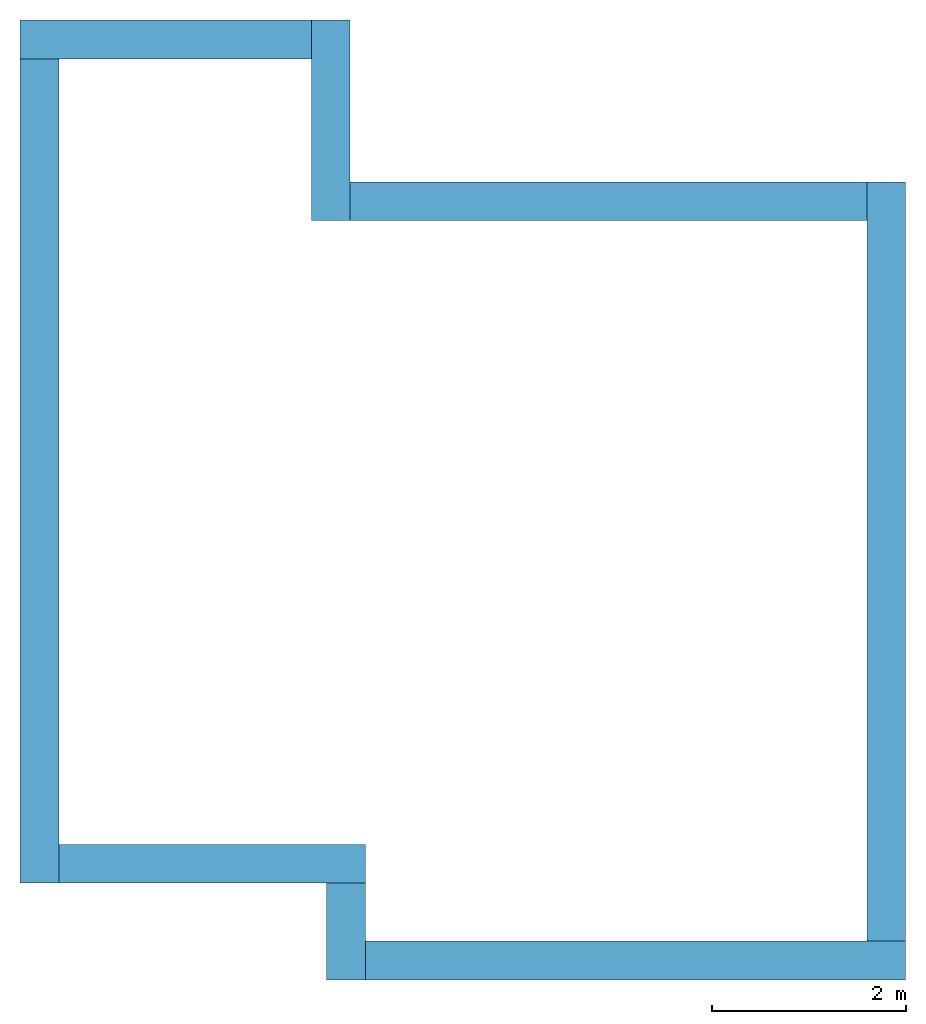
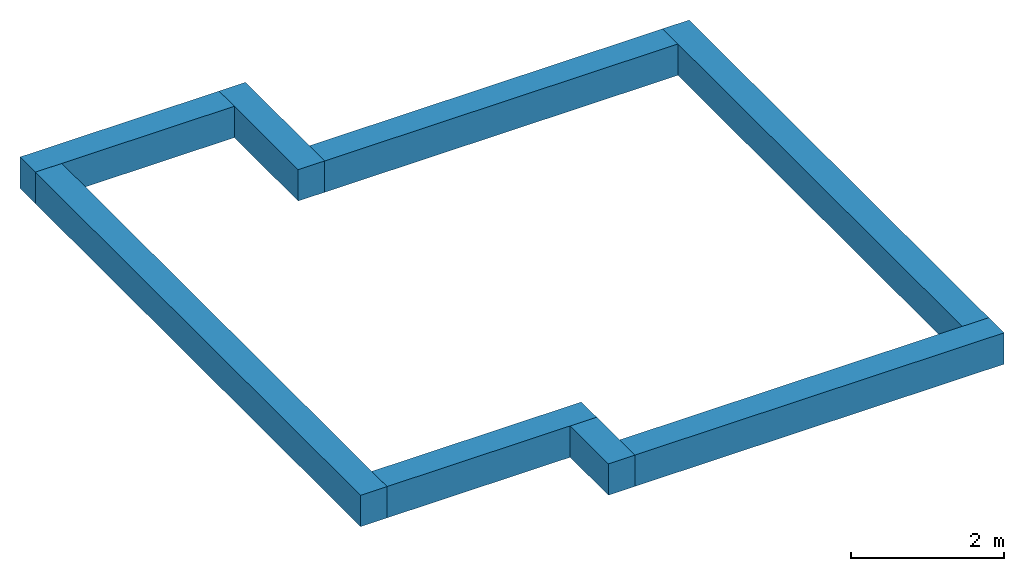
# One storey: 8 beams.
"""IFC4 building model written with IfcOpenShell, lengths in millimetres."""

from ifc_helpers import new_model, entity, si_unit, converted_unit, frame, origin_with_axes, origin_2d_with_axis, place, context, subcontext, project, spatial, rectangle, extrude, material, material_profile, profile_set, profile_usage, type_object, element, save


model = new_model("IFC4")

# Units and contexts
model_context = context("Model", 3, precision=1e-05, world=origin_with_axes())
plan_context = context("Plan", 2, precision=1e-05, world=origin_2d_with_axis())
body_context = subcontext(model_context, "Body", "Model", "MODEL_VIEW")
ifc_project = project(units=[converted_unit("PLANEANGLEUNIT", "degree", entity("IfcReal", 0.0174532925199433), si_unit("PLANEANGLEUNIT", "RADIAN"), dimensions=[0, 0, 0, 0, 0, 0, 0]), si_unit("AREAUNIT", "SQUARE_METRE", prefix="MILLI"), si_unit("VOLUMEUNIT", "CUBIC_METRE", prefix="MILLI"), si_unit("LENGTHUNIT", "METRE", prefix="MILLI")], contexts=[model_context, plan_context])

# Site, building, storey
site_placement = place(None, origin_with_axes())
site = spatial("IfcSite", under=ifc_project, at=site_placement)
building_placement = place(site_placement, origin_with_axes())
building = spatial("IfcBuilding", under=site, at=building_placement, Name="Building")
storey_placement = place(building_placement, frame((0.0, 0.0, -699.999988079071), z_axis=(0.0, 0.0, 1.0), x_axis=(1.0, 0.0, 0.0)))
storey = spatial("IfcBuildingStorey", under=building, at=storey_placement, Name="-01_fundering")

# Beams
ifc_material = material(Name="beton")
ifc_material_profile = material_profile(ifc_material, rectangle(XDim=400.0, YDim=500.0))
ifc_profile_set = profile_set([ifc_material_profile])
ifc_profile_usage_1 = profile_usage(ifc_profile_set, cardinal=3)
beam_type = type_object("IfcBeamType", Name="400x500mm", PredefinedType="BEAM", material=ifc_profile_set)
beam_1_placement = place(storey_placement, frame((13836.4362716675, 2698.16565513611, -0.000536441802978516), z_axis=(1.50995788317232e-07, 1.0, 7.54979012640433e-08), x_axis=(-1.0, 1.50995802528087e-07, -7.54979296857528e-08)))
element("IfcBeam", 1, at=beam_1_placement, inside=storey, type_object=beam_type, material=ifc_profile_usage_1, Name="Beam", context=body_context, shape_type="SweptSolid", body=[
    extrude(rectangle(XDim=400.0, YDim=500.0), frame((200.0, 250.0, 0.0), z_axis=(0.0, 0.0, 1.0), x_axis=(1.0, 0.0, 0.0)), (0.0, 0.0, 1.0), 7829.9970082635),
])
ifc_profile_usage_2 = profile_usage(ifc_profile_set, cardinal=3)
beam_2_placement = place(storey_placement, frame((8107.76233673096, 10128.1642913818, -0.00101327896118164), z_axis=(1.0, -7.54979012640433e-08, 7.54979012640433e-08), x_axis=(7.54979012640433e-08, 1.0, 7.16093850883226e-15)))
element("IfcBeam", 2, at=beam_2_placement, inside=storey, type_object=beam_type, material=ifc_profile_usage_2, Name="Beam", context=body_context, shape_type="SweptSolid", body=[
    extrude(rectangle(XDim=400.0, YDim=500.0), frame((200.0, 250.0, 0.0), z_axis=(0.0, 0.0, 1.0), x_axis=(1.0, 0.0, 0.0)), (0.0, 0.0, 1.0), 5328.67518294392),
])
ifc_profile_usage_3 = profile_usage(ifc_profile_set, cardinal=3)
beam_3_placement = place(storey_placement, frame((8107.76233673096, 10128.1642913818, -0.000655651092529297), z_axis=(1.50995788317232e-07, 1.0, 7.54979012640433e-08), x_axis=(-1.0, 1.50995802528087e-07, -7.54979296857528e-08)))
element("IfcBeam", 3, at=beam_3_placement, inside=storey, type_object=beam_type, material=ifc_profile_usage_3, Name="Beam", context=body_context, shape_type="SweptSolid", body=[
    extrude(rectangle(XDim=400.0, YDim=500.0), frame((200.0, 250.0, 0.0), z_axis=(0.0, 0.0, 1.0), x_axis=(1.0, 0.0, 0.0)), (0.0, 0.0, 1.0), 2068.75321310204),
])
ifc_profile_usage_4 = profile_usage(ifc_profile_set, cardinal=3)
beam_4_placement = place(storey_placement, frame((7707.76271820068, 12196.9175338745, -0.000655651092529297), z_axis=(-1.0, 2.82129974493728e-07, -1.62920684942947e-07), x_axis=(-2.82129974493728e-07, -1.0, -1.19209303761636e-07)))
element("IfcBeam", 4, at=beam_4_placement, inside=storey, type_object=beam_type, material=ifc_profile_usage_4, Name="Beam", context=body_context, shape_type="SweptSolid", body=[
    extrude(rectangle(XDim=400.0, YDim=500.0), frame((200.0, 250.0, 0.0), z_axis=(0.0, 0.0, 1.0), x_axis=(1.0, 0.0, 0.0)), (0.0, 0.0, 1.0), 3003.19723782723),
])
ifc_profile_usage_5 = profile_usage(ifc_profile_set, cardinal=3)
beam_5_placement = place(storey_placement, frame((4704.56552505493, 12196.9175338745, -0.000596046447753906), z_axis=(-3.57627868652344e-07, -1.0, 7.54979012640433e-08), x_axis=(1.0, -3.57627868652344e-07, 1.62920684942947e-07)))
element("IfcBeam", 5, at=beam_5_placement, inside=storey, type_object=beam_type, material=ifc_profile_usage_5, Name="Beam", context=body_context, shape_type="SweptSolid", body=[
    extrude(rectangle(XDim=400.0, YDim=500.0), frame((200.0, 250.0, 0.0), z_axis=(0.0, 0.0, 1.0), x_axis=(1.0, 0.0, 0.0)), (0.0, 0.0, 1.0), 8900.86357127581),
])
ifc_profile_usage_6 = profile_usage(ifc_profile_set, cardinal=3)
beam_6_placement = place(storey_placement, frame((5104.56228256226, 3296.05388641357, -0.000596046447753906), z_axis=(1.0, -7.54979012640433e-08, 7.54979012640433e-08), x_axis=(7.54979012640433e-08, 1.0, 7.16093850883226e-15)))
element("IfcBeam", 6, at=beam_6_placement, inside=storey, type_object=beam_type, material=ifc_profile_usage_6, Name="Beam", context=body_context, shape_type="SweptSolid", body=[
    extrude(rectangle(XDim=400.0, YDim=500.0), frame((200.0, 250.0, 0.0), z_axis=(0.0, 0.0, 1.0), x_axis=(1.0, 0.0, 0.0)), (0.0, 0.0, 1.0), 3162.18989966573),
])
ifc_profile_usage_7 = profile_usage(ifc_profile_set, cardinal=3)
beam_7_placement = place(storey_placement, frame((7866.75262451172, 3296.053647995, -0.000476837158203125), z_axis=(-3.57627868652344e-07, -1.0, 7.54979012640433e-08), x_axis=(1.0, -3.57627868652344e-07, 1.62920684942947e-07)))
element("IfcBeam", 7, at=beam_7_placement, inside=storey, type_object=beam_type, material=ifc_profile_usage_7, Name="Beam", context=body_context, shape_type="SweptSolid", body=[
    extrude(rectangle(XDim=400.0, YDim=500.0), frame((200.0, 250.0, 0.0), z_axis=(0.0, 0.0, 1.0), x_axis=(1.0, 0.0, 0.0)), (0.0, 0.0, 1.0), 997.887376555967),
])
ifc_profile_usage_8 = profile_usage(ifc_profile_set, cardinal=3)
beam_8_placement = place(storey_placement, frame((8266.75224304199, 2298.16627502441, -0.000536441802978516), z_axis=(1.0, -7.54979012640433e-08, 7.54979012640433e-08), x_axis=(7.54979012640433e-08, 1.0, 7.16093850883226e-15)))
element("IfcBeam", 8, at=beam_8_placement, inside=storey, type_object=beam_type, material=ifc_profile_usage_8, Name="Beam", context=body_context, shape_type="SweptSolid", body=[
    extrude(rectangle(XDim=400.0, YDim=500.0), frame((200.0, 250.0, 0.0), z_axis=(0.0, 0.0, 1.0), x_axis=(1.0, 0.0, 0.0)), (0.0, 0.0, 1.0), 5569.68396507608),
])

save(model, "model.ifc")
